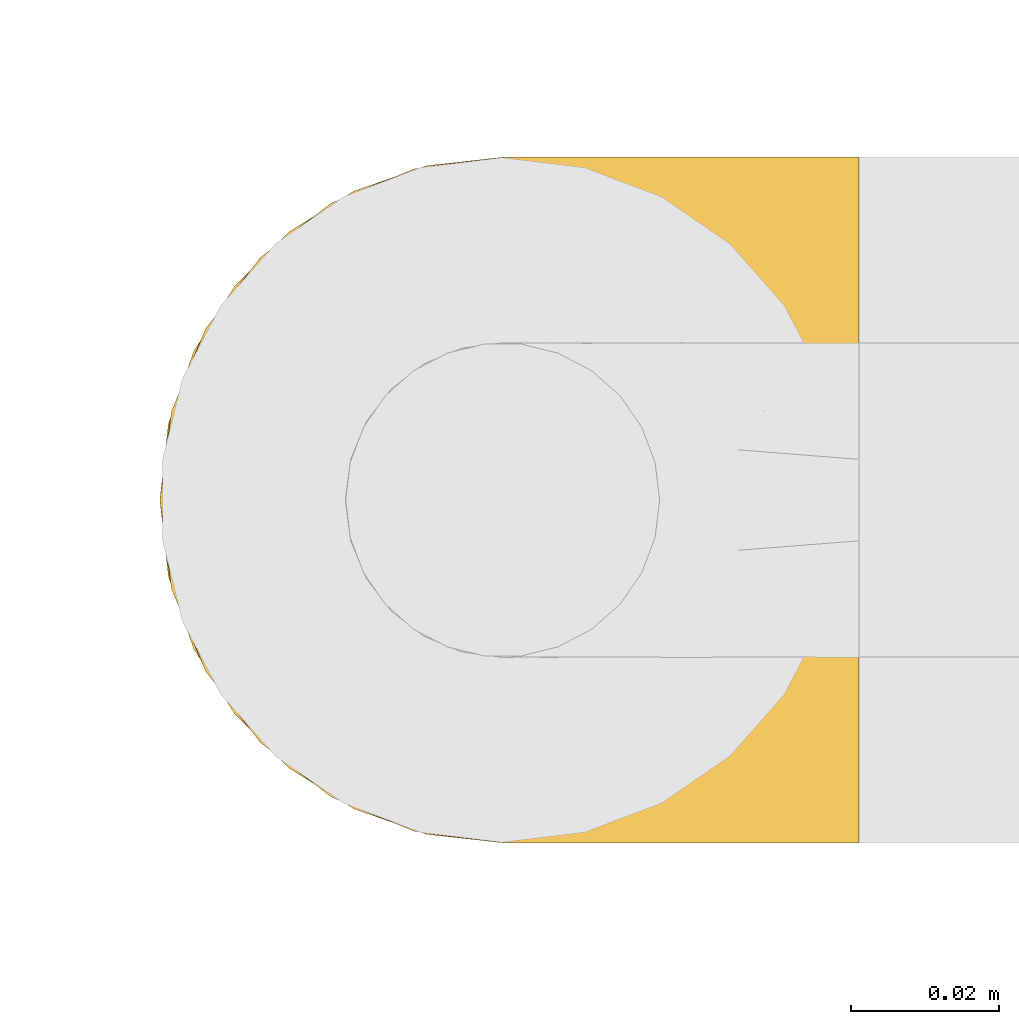
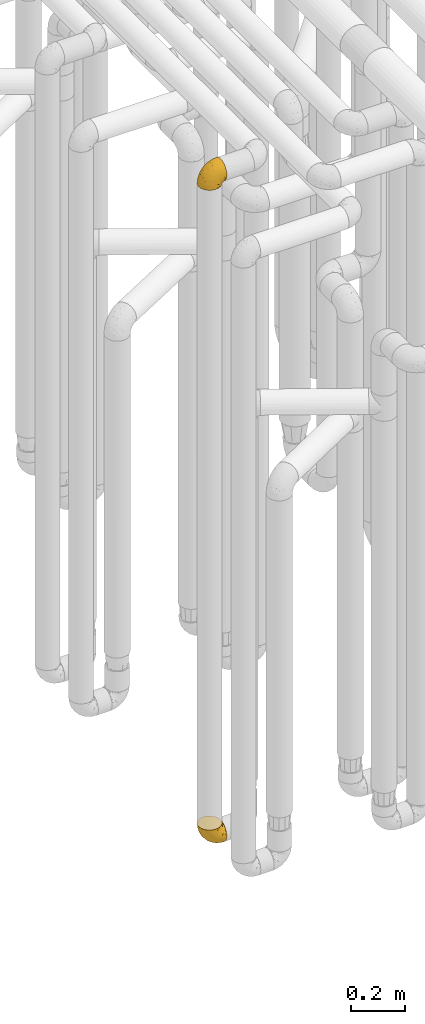
# One storey, part 153 of 827: 2 coverings.
"""IFC2X3 building model written with IfcOpenShell, lengths in millimetres."""

from ifc_helpers import new_model, entity, si_unit, converted_unit, derived_unit, direction, frame, origin, place, context, subcontext, project, spatial, faceted_brep, element, save


model = new_model("IFC2X3")

# Units and contexts
model_context = context("Model", 3, precision=0.01, world=origin(), true_north=direction((6.12303176911189e-17, 1.0)))
body_context = subcontext(model_context, "Body", "Model", "MODEL_VIEW")
ifc_project = project(units=[si_unit("LENGTHUNIT", "METRE", prefix="MILLI"), si_unit("AREAUNIT", "SQUARE_METRE"), si_unit("VOLUMEUNIT", "CUBIC_METRE"), converted_unit("PLANEANGLEUNIT", "DEGREE", entity("IfcRatioMeasure", 0.0174532925199433), si_unit("PLANEANGLEUNIT", "RADIAN"), dimensions=[0, 0, 0, 0, 0, 0, 0]), si_unit("MASSUNIT", "GRAM", prefix="KILO"), derived_unit("MASSDENSITYUNIT", [(si_unit("MASSUNIT", "GRAM", prefix="KILO"), 1), (si_unit("LENGTHUNIT", "METRE"), -3)]), derived_unit("MOMENTOFINERTIAUNIT", [(si_unit("LENGTHUNIT", "METRE"), 4)]), si_unit("TIMEUNIT", "SECOND"), si_unit("FREQUENCYUNIT", "HERTZ"), si_unit("THERMODYNAMICTEMPERATUREUNIT", "DEGREE_CELSIUS"), derived_unit("THERMALTRANSMITTANCEUNIT", [(si_unit("MASSUNIT", "GRAM", prefix="KILO"), 1), (si_unit("THERMODYNAMICTEMPERATUREUNIT", "KELVIN"), -1), (si_unit("TIMEUNIT", "SECOND"), -3)]), derived_unit("VOLUMETRICFLOWRATEUNIT", [(si_unit("LENGTHUNIT", "METRE"), 3), (si_unit("TIMEUNIT", "SECOND"), -1)]), derived_unit("MASSFLOWRATEUNIT", [(si_unit("MASSUNIT", "GRAM", prefix="KILO"), 1), (si_unit("TIMEUNIT", "SECOND"), -1)]), derived_unit("ROTATIONALFREQUENCYUNIT", [(si_unit("TIMEUNIT", "SECOND"), -1)]), si_unit("ELECTRICCURRENTUNIT", "AMPERE"), si_unit("ELECTRICVOLTAGEUNIT", "VOLT"), si_unit("POWERUNIT", "WATT"), si_unit("FORCEUNIT", "NEWTON", prefix="KILO"), si_unit("ILLUMINANCEUNIT", "LUX"), si_unit("LUMINOUSFLUXUNIT", "LUMEN"), si_unit("LUMINOUSINTENSITYUNIT", "CANDELA"), derived_unit("USERDEFINED", [(si_unit("MASSUNIT", "GRAM", prefix="KILO"), -1), (si_unit("LENGTHUNIT", "METRE"), -2), (si_unit("TIMEUNIT", "SECOND"), 3), (si_unit("LUMINOUSFLUXUNIT", "LUMEN"), 1)]), derived_unit("LINEARVELOCITYUNIT", [(si_unit("LENGTHUNIT", "METRE"), 1), (si_unit("TIMEUNIT", "SECOND"), -1)]), si_unit("PRESSUREUNIT", "PASCAL"), derived_unit("USERDEFINED", [(si_unit("LENGTHUNIT", "METRE"), -2), (si_unit("MASSUNIT", "GRAM", prefix="KILO"), 1), (si_unit("TIMEUNIT", "SECOND"), -2)]), derived_unit("LINEARFORCEUNIT", [(si_unit("MASSUNIT", "GRAM", prefix="KILO"), 1), (si_unit("LENGTHUNIT", "METRE"), 1), (si_unit("TIMEUNIT", "SECOND"), -2), (si_unit("LENGTHUNIT", "METRE"), -1)]), derived_unit("PLANARFORCEUNIT", [(si_unit("MASSUNIT", "GRAM", prefix="KILO"), 1), (si_unit("LENGTHUNIT", "METRE"), 1), (si_unit("TIMEUNIT", "SECOND"), -2), (si_unit("LENGTHUNIT", "METRE"), -2)])], contexts=[model_context])

# Site, building, storey
site_placement = place(None, origin())
site = spatial("IfcSite", under=ifc_project, at=site_placement, CompositionType="ELEMENT")
building_placement = place(site_placement, origin())
building = spatial("IfcBuilding", under=site, at=building_placement, CompositionType="ELEMENT")
storey_placement = place(building_placement, frame((0.0, 0.0, 28200.0)))
storey = spatial("IfcBuildingStorey", under=building, at=storey_placement, Name="08", CompositionType="ELEMENT", Elevation=28200.0)

# Coverings
covering_1_placement = place(storey_placement, frame((35077.24, 10561.35, 352.2)))
element("IfcCovering", 1, at=covering_1_placement, inside=storey, Name=":ADSK_", ObjectType=":ADSK_", PredefinedType="INSULATION", context=body_context, shape_type="Brep", body=[
    faceted_brep([(18.98, 83.91, 95.8), (11.67, 76.59, 95.8), (6.17, 67.83, 95.8), (2.75, 58.07, 95.8), (1.6, 47.8, 95.8), (2.75, 37.51, 95.8), (6.17, 27.74, 95.8), (11.68, 18.98, 95.8), (19.0, 11.67, 95.8), (27.76, 6.17, 95.8), (37.52, 2.75, 95.8), (47.8, 1.6, 95.8), (51.94, 2.06, 95.8), (55.01, 2.41, 95.8), (58.08, 2.75, 95.8), (62.96, 4.46, 95.8), (67.85, 6.17, 95.8), (72.23, 8.93, 95.8), (76.61, 11.68, 95.8), (80.26, 15.34, 95.8), (83.92, 19.0, 95.8), (89.42, 27.76, 95.8), (91.13, 32.64, 95.8), (92.84, 37.52, 95.8), (94.0, 47.8, 95.8), (92.84, 58.08, 95.8), (91.13, 62.96, 95.8), (89.42, 67.85, 95.8), (83.91, 76.61, 95.8), (80.25, 80.26, 95.8), (76.59, 83.92, 95.8), (72.21, 86.67, 95.8), (67.83, 89.42, 95.8), (62.95, 91.13, 95.8), (58.07, 92.84, 95.8), (55.0, 93.18, 95.8), (51.94, 93.53, 95.8), (47.8, 94.0, 95.8), (37.51, 92.84, 95.8), (27.74, 89.42, 95.8), (95.8, 47.8, 94.0), (95.8, 35.84, 92.42), (95.8, 24.7, 87.81), (95.8, 19.91, 84.13), (95.8, 15.13, 80.46), (95.8, 11.46, 75.68), (95.8, 7.78, 70.9), (95.8, 5.48, 65.32), (95.8, 3.17, 59.75), (95.8, 2.69, 56.14), (95.8, 2.42, 54.06), (95.8, 2.14, 51.97), (95.8, 1.6, 47.8), (95.8, 3.17, 35.84), (95.8, 7.78, 24.7), (95.8, 15.13, 15.13), (95.8, 24.7, 7.78), (95.8, 35.84, 3.17), (95.8, 47.8, 1.6), (95.8, 59.75, 3.17), (95.8, 70.9, 7.78), (95.8, 80.46, 15.13), (95.8, 87.81, 24.7), (95.8, 92.42, 35.84), (95.8, 94.0, 47.8), (95.8, 93.45, 51.97), (95.8, 92.9, 56.14), (95.8, 92.42, 59.75), (95.8, 90.11, 65.32), (95.8, 87.81, 70.9), (95.8, 84.13, 75.68), (95.8, 80.46, 80.46), (95.8, 75.68, 84.13), (95.8, 70.9, 87.81), (95.8, 59.75, 92.42), (60.58, 71.98, 15.84), (74.11, 63.6, 6.99), (51.59, 59.72, 14.39), (66.69, 47.8, 6.21), (76.19, 55.16, 4.26), (84.43, 47.8, 3.39), (31.2, 63.76, 31.2), (42.88, 72.22, 26.47), (79.41, 74.18, 11.44), (60.7, 92.52, 47.66), (61.85, 94.0, 61.85), (65.75, 94.0, 59.25), (69.64, 94.0, 56.65), (73.53, 94.0, 54.05), (77.43, 94.0, 51.45), (74.59, 82.14, 19.8), (54.72, 80.34, 26.22), (64.18, 87.52, 31.58), (37.94, 79.59, 38.36), (25.89, 78.25, 51.54), (34.73, 85.01, 51.6), (42.89, 90.25, 55.97), (49.83, 93.2, 62.88), (48.58, 87.23, 41.35), (22.41, 85.55, 82.24), (78.69, 93.0, 40.88), (81.64, 89.31, 29.0), (6.22, 61.31, 74.06), (12.11, 56.86, 54.53), (14.81, 68.34, 57.98), (21.61, 65.71, 43.81), (22.41, 56.99, 38.22), (30.12, 72.15, 38.33), (10.01, 70.34, 74.76), (15.36, 78.36, 76.85), (3.39, 47.8, 84.43), (19.59, 47.8, 40.43), (30.01, 47.8, 30.01), (41.19, 93.06, 78.67), (48.54, 94.0, 92.06), (49.28, 94.0, 88.32), (49.82, 94.0, 85.6), (50.37, 94.0, 82.88), (50.91, 94.0, 80.15), (51.45, 94.0, 77.43), (31.61, 89.88, 76.36), (80.15, 94.0, 50.91), (82.88, 94.0, 50.37), (85.6, 94.0, 49.82), (88.32, 94.0, 49.28), (90.19, 94.0, 48.91), (92.06, 94.0, 48.54), (6.21, 47.8, 66.69), (54.05, 94.0, 73.53), (56.65, 94.0, 69.64), (59.25, 94.0, 65.75), (24.66, 83.7, 66.13), (40.43, 47.8, 19.59), (35.17, 55.9, 24.64), (12.9, 47.8, 53.56), (53.56, 47.8, 12.9), (85.34, 81.75, 82.81), (78.44, 86.43, 81.22), (84.37, 79.8, 86.57), (89.05, 69.84, 92.75), (82.76, 79.5, 89.68), (86.31, 88.08, 72.26), (83.73, 91.6, 64.73), (77.31, 92.93, 62.45), (87.78, 92.43, 60.63), (87.91, 93.24, 56.91), (81.29, 93.36, 58.14), (93.97, 57.25, 93.7), (70.76, 89.41, 83.4), (63.67, 92.89, 75.54), (62.62, 92.66, 79.46), (90.64, 79.58, 82.28), (84.08, 86.51, 76.25), (76.28, 86.29, 84.69), (77.45, 83.91, 90.18), (88.72, 90.94, 65.12), (71.28, 91.94, 71.71), (68.09, 91.98, 75.21), (91.07, 82.79, 78.6), (57.47, 93.16, 87.27), (70.34, 88.76, 87.92), (91.35, 73.94, 86.94), (62.99, 91.89, 86.1), (94.52, 47.8, 94.52), (76.47, 92.22, 66.23), (69.96, 88.56, 91.08), (89.86, 87.72, 71.77), (78.94, 88.33, 76.21), (73.51, 92.18, 68.59), (89.62, 71.78, 89.94), (84.09, 9.09, 76.25), (86.3, 7.51, 72.26), (91.06, 12.8, 78.6), (88.32, 1.6, 49.28), (92.06, 1.6, 48.54), (82.88, 1.6, 50.37), (85.6, 1.6, 49.82), (93.97, 38.35, 93.7), (89.63, 23.84, 89.95), (50.37, 1.6, 82.88), (49.82, 1.6, 85.6), (48.54, 1.6, 92.06), (49.28, 1.6, 88.32), (82.77, 16.1, 89.68), (70.36, 6.84, 87.92), (77.31, 2.66, 62.45), (76.47, 3.37, 66.24), (69.64, 1.6, 56.65), (65.75, 1.6, 59.25), (87.78, 3.16, 60.63), (87.91, 2.35, 56.91), (89.06, 25.77, 92.76), (90.65, 16.02, 82.28), (85.35, 13.85, 82.81), (73.53, 1.6, 54.05), (77.43, 1.6, 51.45), (81.29, 2.23, 58.14), (77.46, 11.69, 90.18), (76.29, 9.31, 84.7), (57.47, 2.43, 87.25), (63.71, 2.71, 75.58), (68.11, 3.61, 75.2), (70.77, 6.18, 83.39), (71.31, 3.66, 71.7), (78.46, 9.17, 81.22), (69.52, 6.77, 90.73), (62.64, 2.93, 79.47), (91.35, 21.66, 86.94), (59.25, 1.6, 65.75), (84.6, 16.09, 86.75), (62.98, 3.7, 86.08), (51.45, 1.6, 77.43), (54.05, 1.6, 73.53), (56.65, 1.6, 69.64), (83.73, 3.99, 64.73), (80.15, 1.6, 50.91), (88.72, 4.65, 65.12), (61.85, 1.6, 61.85), (73.56, 3.43, 68.62), (78.96, 7.27, 76.22), (91.36, 9.46, 74.03), (50.91, 1.6, 80.15), (62.87, 2.4, 49.81), (76.19, 40.43, 4.26), (73.57, 13.57, 19.95), (56.07, 11.3, 30.61), (49.77, 18.65, 25.71), (44.73, 27.26, 22.43), (60.58, 23.61, 15.85), (47.64, 3.07, 60.69), (78.32, 2.69, 40.49), (51.59, 35.87, 14.39), (74.11, 31.99, 6.99), (76.04, 6.71, 29.56), (79.41, 21.41, 11.45), (14.82, 27.24, 57.98), (6.22, 34.26, 74.06), (12.12, 38.73, 54.52), (23.51, 26.97, 43.47), (31.2, 31.83, 31.2), (34.96, 23.4, 33.27), (33.86, 6.91, 64.26), (38.94, 3.4, 74.29), (30.23, 5.84, 80.41), (35.17, 39.69, 24.64), (15.85, 17.6, 73.62), (22.59, 10.38, 78.98), (21.56, 20.6, 53.69), (55.94, 5.36, 42.86), (20.67, 35.73, 41.67), (9.19, 24.84, 79.66), (25.79, 13.87, 58.41), (41.16, 9.06, 47.11), (37.95, 15.99, 38.37)], [[[0, 1, 2, 3, 4, 5, 6, 7, 8, 9, 10, 11, 12, 13, 14, 15, 16, 17, 18, 19, 20, 21, 22, 23, 24, 25, 26, 27, 28, 29, 30, 31, 32, 33, 34, 35, 36, 37, 38, 39]], [[40, 41, 42, 43, 44, 45, 46, 47, 48, 49, 50, 51, 52, 53, 54, 55, 56, 57, 58, 59, 60, 61, 62, 63, 64, 65, 66, 67, 68, 69, 70, 71, 72, 73, 74]], [[75, 76, 77]], [[78, 79, 80]], [[77, 81, 82]], [[76, 75, 83]], [[84, 85, 86, 87, 88, 89]], [[90, 91, 92]], [[76, 60, 59]], [[93, 94, 95]], [[90, 62, 61]], [[83, 61, 60]], [[96, 97, 84]], [[98, 93, 95]], [[0, 39, 99]], [[100, 84, 89]], [[62, 101, 63]], [[2, 102, 3]], [[92, 84, 100]], [[103, 102, 104]], [[103, 105, 106]], [[93, 107, 94]], [[1, 108, 2]], [[92, 101, 90]], [[108, 1, 109]], [[102, 110, 3]], [[93, 82, 107]], [[102, 108, 104]], [[111, 106, 112]], [[109, 0, 99]], [[113, 37, 114, 115, 116, 117, 118, 119]], [[120, 38, 113]], [[100, 89, 121, 122, 123, 124, 125, 126, 64]], [[127, 102, 103]], [[97, 119, 128, 129, 130, 85]], [[99, 120, 131]], [[132, 133, 77]], [[59, 80, 79]], [[1, 0, 109]], [[98, 84, 92]], [[94, 109, 131]], [[120, 39, 38]], [[93, 91, 82]], [[104, 94, 105]], [[97, 113, 119]], [[95, 120, 96]], [[83, 90, 61]], [[91, 93, 98]], [[64, 63, 100]], [[100, 63, 101]], [[77, 76, 79]], [[133, 106, 81]], [[84, 97, 85]], [[113, 96, 120]], [[113, 97, 96]], [[37, 113, 38]], [[110, 102, 127]], [[110, 4, 3]], [[103, 111, 134, 127]], [[90, 75, 91]], [[82, 81, 107]], [[91, 75, 82]], [[77, 82, 75]], [[76, 83, 60]], [[90, 83, 75]], [[105, 107, 81]], [[94, 131, 95]], [[105, 94, 107]], [[109, 94, 104]], [[120, 95, 131]], [[98, 95, 96]], [[84, 98, 96]], [[98, 92, 91]], [[106, 105, 81]], [[103, 104, 105]], [[112, 106, 133]], [[103, 106, 111]], [[112, 133, 132]], [[81, 77, 133]], [[77, 78, 135, 132]], [[120, 99, 39]], [[109, 99, 131]], [[59, 58, 80]], [[59, 79, 76]], [[90, 101, 62]], [[100, 101, 92]], [[2, 108, 102]], [[109, 104, 108]], [[78, 77, 79]], [[136, 137, 138]], [[27, 139, 140]], [[141, 142, 143]], [[144, 145, 121]], [[146, 89, 88]], [[147, 139, 25]], [[148, 149, 150]], [[136, 151, 152]], [[147, 40, 74]], [[24, 147, 25]], [[140, 153, 154]], [[33, 116, 34]], [[73, 72, 151]], [[114, 37, 36, 35, 34, 116, 115]], [[146, 155, 144]], [[156, 85, 130]], [[157, 149, 148]], [[151, 158, 152]], [[117, 33, 159]], [[29, 154, 160]], [[161, 74, 73]], [[162, 128, 119]], [[66, 65, 64, 126, 125, 124, 123, 122, 67]], [[163, 147, 24]], [[27, 140, 28]], [[149, 129, 150]], [[139, 27, 26, 25]], [[68, 144, 69]], [[129, 128, 150]], [[164, 87, 86]], [[130, 129, 149]], [[122, 145, 67]], [[154, 153, 148]], [[162, 119, 159]], [[165, 30, 160]], [[150, 160, 148]], [[128, 162, 150]], [[30, 165, 31]], [[145, 144, 68]], [[89, 146, 144]], [[87, 164, 143]], [[166, 155, 142]], [[88, 87, 143]], [[162, 160, 150]], [[160, 30, 29]], [[154, 29, 28]], [[140, 154, 28]], [[160, 154, 148]], [[140, 137, 153]], [[157, 148, 153]], [[156, 130, 157]], [[153, 137, 157]], [[157, 137, 156]], [[167, 137, 136]], [[168, 85, 156]], [[152, 168, 167]], [[167, 168, 156]], [[164, 152, 141]], [[71, 158, 72]], [[152, 167, 136]], [[88, 142, 146]], [[144, 155, 69]], [[146, 142, 155]], [[70, 166, 71]], [[142, 141, 166]], [[70, 69, 155]], [[141, 158, 71]], [[161, 73, 151]], [[138, 137, 140]], [[161, 136, 169]], [[136, 161, 151]], [[74, 161, 169]], [[152, 158, 141]], [[151, 72, 158]], [[168, 152, 164]], [[137, 167, 156]], [[164, 86, 168]], [[85, 168, 86]], [[116, 33, 117]], [[130, 149, 157]], [[67, 145, 68]], [[121, 89, 144]], [[145, 122, 121]], [[40, 147, 163]], [[169, 147, 74]], [[159, 33, 32]], [[162, 159, 32]], [[159, 119, 118, 117]], [[139, 147, 169]], [[139, 169, 138]], [[162, 32, 31]], [[141, 143, 164]], [[88, 143, 142]], [[71, 166, 141]], [[155, 166, 70]], [[139, 138, 140]], [[169, 136, 138]], [[160, 162, 165]], [[162, 31, 165]], [[170, 171, 172]], [[173, 174, 52, 51, 50, 49, 48, 175, 176]], [[177, 178, 41]], [[179, 15, 180]], [[12, 11, 181, 182, 180, 14, 13]], [[183, 21, 20]], [[19, 18, 184]], [[185, 186, 187]], [[186, 188, 187]], [[43, 172, 44]], [[189, 190, 47]], [[23, 22, 21, 191]], [[170, 192, 193]], [[40, 163, 177]], [[194, 195, 196]], [[24, 23, 177]], [[197, 198, 183]], [[199, 15, 179]], [[47, 46, 189]], [[200, 201, 202]], [[201, 203, 204]], [[205, 206, 184]], [[207, 41, 178]], [[16, 15, 199]], [[14, 180, 15]], [[202, 201, 198]], [[208, 201, 200]], [[163, 24, 177]], [[48, 47, 190]], [[196, 195, 189]], [[197, 184, 202]], [[204, 193, 209]], [[210, 211, 212]], [[206, 212, 213]], [[205, 17, 210]], [[184, 206, 202]], [[210, 212, 206]], [[185, 194, 214]], [[189, 215, 190]], [[216, 45, 214]], [[186, 171, 170]], [[189, 216, 196]], [[197, 20, 19]], [[194, 185, 187]], [[197, 183, 20]], [[184, 197, 19]], [[197, 202, 198]], [[206, 200, 202]], [[204, 183, 198]], [[201, 208, 203]], [[203, 208, 217]], [[204, 198, 201]], [[217, 188, 218]], [[193, 219, 170]], [[171, 186, 185]], [[170, 218, 186]], [[170, 219, 218]], [[42, 207, 192]], [[171, 220, 172]], [[216, 189, 46]], [[214, 194, 196]], [[44, 220, 45]], [[214, 196, 216]], [[216, 46, 45]], [[214, 45, 220]], [[192, 43, 42]], [[204, 203, 219]], [[207, 193, 192]], [[209, 193, 178]], [[41, 207, 42]], [[193, 207, 178]], [[43, 192, 172]], [[170, 172, 192]], [[204, 219, 193]], [[219, 203, 218]], [[217, 218, 203]], [[188, 186, 218]], [[206, 213, 200]], [[208, 200, 213]], [[199, 210, 16]], [[215, 189, 195]], [[215, 175, 190]], [[175, 48, 190]], [[199, 179, 221, 211]], [[210, 199, 211]], [[23, 191, 177]], [[40, 177, 41]], [[178, 177, 191]], [[21, 183, 191]], [[209, 191, 183]], [[205, 18, 17]], [[17, 16, 210]], [[171, 185, 214]], [[172, 220, 44]], [[214, 220, 171]], [[191, 209, 178]], [[204, 209, 183]], [[206, 205, 210]], [[18, 205, 184]], [[222, 195, 194, 187, 188, 217]], [[57, 223, 80]], [[224, 225, 226]], [[226, 227, 228]], [[229, 217, 208, 213, 212, 211]], [[230, 52, 174, 173, 176, 175, 215, 195]], [[231, 232, 228]], [[231, 78, 223]], [[223, 57, 232]], [[224, 233, 225]], [[233, 54, 53]], [[234, 232, 56]], [[56, 55, 234]], [[234, 224, 228]], [[235, 236, 237]], [[224, 55, 54]], [[238, 239, 240]], [[52, 230, 53]], [[241, 242, 243]], [[227, 244, 231]], [[11, 10, 242]], [[236, 6, 5]], [[7, 245, 8]], [[8, 246, 9]], [[238, 247, 235]], [[222, 229, 248]], [[242, 211, 221, 179, 180, 182, 181, 11]], [[233, 53, 230]], [[111, 112, 249]], [[250, 6, 236]], [[246, 251, 241]], [[6, 250, 7]], [[127, 236, 110]], [[248, 229, 252]], [[246, 8, 245]], [[235, 245, 250]], [[236, 5, 110]], [[235, 249, 238]], [[237, 236, 127]], [[243, 9, 246]], [[252, 229, 241]], [[56, 232, 57]], [[222, 230, 195]], [[225, 248, 252]], [[248, 233, 230]], [[54, 233, 224]], [[231, 228, 227]], [[244, 132, 231]], [[248, 225, 233]], [[226, 225, 253]], [[235, 250, 236]], [[245, 7, 250]], [[251, 246, 245]], [[243, 246, 241]], [[247, 245, 235]], [[252, 251, 253]], [[229, 222, 217]], [[230, 222, 248]], [[5, 4, 110]], [[237, 127, 134, 111]], [[238, 249, 239]], [[224, 234, 55]], [[232, 234, 228]], [[242, 241, 229]], [[10, 9, 243]], [[211, 242, 229]], [[10, 243, 242]], [[80, 223, 78]], [[80, 58, 57]], [[231, 223, 232]], [[227, 240, 239]], [[224, 226, 228]], [[240, 226, 253]], [[227, 239, 244]], [[226, 240, 227]], [[251, 247, 253]], [[240, 253, 247]], [[249, 235, 237]], [[237, 111, 249]], [[112, 132, 244]], [[112, 244, 249]], [[78, 231, 132, 135]], [[249, 244, 239]], [[247, 238, 240]], [[245, 247, 251]], [[251, 252, 241]], [[225, 252, 253]]]),
])
covering_2_placement = place(storey_placement, frame((35077.24, 10561.35, 3350.4)))
element("IfcCovering", 2, at=covering_2_placement, inside=storey, Name=":ADSK_", ObjectType=":ADSK_", PredefinedType="INSULATION", context=body_context, shape_type="Brep", body=[
    faceted_brep([(95.8, 83.91, 78.41), (95.8, 76.59, 85.72), (95.8, 67.83, 91.22), (95.8, 58.07, 94.64), (95.8, 47.8, 95.8), (95.8, 37.51, 94.64), (95.8, 27.74, 91.22), (95.8, 18.98, 85.71), (95.8, 11.67, 78.39), (95.8, 6.17, 69.63), (95.8, 2.75, 59.87), (95.8, 1.6, 49.6), (95.8, 2.06, 45.45), (95.8, 2.41, 42.38), (95.8, 2.75, 39.31), (95.8, 4.46, 34.43), (95.8, 6.17, 29.54), (95.8, 8.93, 25.16), (95.8, 11.68, 20.78), (95.8, 15.34, 17.13), (95.8, 19.0, 13.47), (95.8, 27.76, 7.97), (95.8, 32.64, 6.26), (95.8, 37.52, 4.55), (95.8, 47.8, 3.4), (95.8, 58.08, 4.55), (95.8, 62.96, 6.26), (95.8, 67.85, 7.97), (95.8, 76.61, 13.48), (95.8, 80.26, 17.14), (95.8, 83.92, 20.8), (95.8, 86.67, 25.18), (95.8, 89.42, 29.56), (95.8, 91.13, 34.44), (95.8, 92.84, 39.32), (95.8, 93.18, 42.39), (95.8, 93.53, 45.45), (95.8, 94.0, 49.6), (95.8, 92.84, 59.88), (95.8, 89.42, 69.65), (94.0, 47.8, 1.6), (92.42, 35.84, 1.6), (87.81, 24.7, 1.6), (84.13, 19.91, 1.6), (80.46, 15.13, 1.6), (75.68, 11.46, 1.6), (70.9, 7.78, 1.6), (65.32, 5.48, 1.6), (59.75, 3.17, 1.6), (56.14, 2.69, 1.6), (54.06, 2.42, 1.6), (51.97, 2.14, 1.6), (47.8, 1.6, 1.6), (35.84, 3.17, 1.6), (24.7, 7.78, 1.6), (15.13, 15.13, 1.6), (7.78, 24.7, 1.6), (3.17, 35.84, 1.6), (1.6, 47.8, 1.6), (3.17, 59.75, 1.6), (7.78, 70.9, 1.6), (15.13, 80.46, 1.6), (24.7, 87.81, 1.6), (35.84, 92.42, 1.6), (47.8, 94.0, 1.6), (51.97, 93.45, 1.6), (56.14, 92.9, 1.6), (59.75, 92.42, 1.6), (65.32, 90.11, 1.6), (70.9, 87.81, 1.6), (75.68, 84.13, 1.6), (80.46, 80.46, 1.6), (84.13, 75.68, 1.6), (87.81, 70.9, 1.6), (92.42, 59.75, 1.6), (15.84, 71.98, 36.81), (6.99, 63.6, 23.28), (14.39, 59.72, 45.8), (6.21, 47.8, 30.7), (4.26, 55.16, 21.2), (3.39, 47.8, 12.96), (31.2, 63.76, 66.19), (26.47, 72.22, 54.51), (11.44, 74.18, 17.98), (47.66, 92.52, 36.69), (61.85, 94.0, 35.54), (59.25, 94.0, 31.64), (56.65, 94.0, 27.75), (54.05, 94.0, 23.86), (51.45, 94.0, 19.96), (19.8, 82.14, 22.8), (26.22, 80.34, 42.67), (31.58, 87.52, 33.21), (38.36, 79.59, 59.45), (51.54, 78.25, 71.5), (51.6, 85.01, 62.66), (55.97, 90.25, 54.5), (62.88, 93.2, 47.57), (41.35, 87.23, 48.81), (82.24, 85.55, 74.98), (40.88, 93.0, 18.7), (29.0, 89.31, 15.75), (74.06, 61.31, 91.17), (54.53, 56.86, 85.28), (57.98, 68.34, 82.58), (43.81, 65.71, 75.78), (38.22, 56.99, 74.98), (38.33, 72.15, 67.27), (74.76, 70.34, 87.38), (76.85, 78.36, 82.04), (84.43, 47.8, 94.0), (40.43, 47.8, 77.8), (30.01, 47.8, 67.38), (78.67, 93.06, 56.2), (92.06, 94.0, 48.85), (88.32, 94.0, 48.11), (85.6, 94.0, 47.57), (82.88, 94.0, 47.03), (80.15, 94.0, 46.48), (77.43, 94.0, 45.94), (76.36, 89.88, 65.78), (50.91, 94.0, 17.24), (50.37, 94.0, 14.51), (49.82, 94.0, 11.79), (49.28, 94.0, 9.07), (48.91, 94.0, 7.2), (48.54, 94.0, 5.33), (66.69, 47.8, 91.18), (73.53, 94.0, 43.34), (69.64, 94.0, 40.74), (65.75, 94.0, 38.14), (66.13, 83.7, 72.73), (19.59, 47.8, 56.96), (24.64, 55.9, 62.23), (53.56, 47.8, 84.49), (12.9, 47.8, 43.83), (82.81, 81.75, 12.05), (81.22, 86.43, 18.95), (86.57, 79.8, 13.02), (92.75, 69.84, 8.34), (89.68, 79.5, 14.63), (72.26, 88.08, 11.09), (64.73, 91.6, 13.66), (62.45, 92.93, 20.08), (60.63, 92.43, 9.61), (56.91, 93.24, 9.48), (58.14, 93.36, 16.1), (93.7, 57.25, 3.42), (83.4, 89.41, 26.63), (75.54, 92.89, 33.72), (79.46, 92.66, 34.77), (82.28, 79.58, 6.75), (76.25, 86.51, 13.31), (90.18, 83.91, 19.94), (84.69, 86.29, 21.11), (86.94, 73.94, 6.04), (65.12, 90.94, 8.67), (71.71, 91.94, 26.11), (75.21, 91.98, 29.3), (78.6, 82.79, 6.32), (87.27, 93.16, 39.92), (87.92, 88.76, 27.05), (86.1, 91.89, 34.4), (94.52, 47.8, 2.87), (66.23, 92.22, 20.92), (91.08, 88.56, 27.43), (71.77, 87.72, 7.54), (76.21, 88.33, 18.45), (68.59, 92.18, 23.88), (89.94, 71.78, 7.77), (76.22, 7.27, 18.43), (81.22, 9.17, 18.93), (71.7, 3.66, 26.08), (49.28, 1.6, 9.07), (48.54, 1.6, 5.33), (50.37, 1.6, 14.51), (49.82, 1.6, 11.79), (93.7, 38.35, 3.42), (89.95, 23.84, 7.76), (82.88, 1.6, 47.03), (85.6, 1.6, 47.57), (92.06, 1.6, 48.85), (88.32, 1.6, 48.11), (89.68, 16.1, 14.62), (87.92, 6.84, 27.03), (62.45, 2.66, 20.08), (66.24, 3.37, 20.92), (56.65, 1.6, 27.75), (59.25, 1.6, 31.64), (78.6, 12.8, 6.33), (60.63, 3.16, 9.61), (56.91, 2.35, 9.48), (92.76, 25.77, 8.33), (76.25, 9.09, 13.3), (82.28, 16.02, 6.74), (82.81, 13.85, 12.04), (54.05, 1.6, 23.86), (51.45, 1.6, 19.96), (58.14, 2.23, 16.1), (90.18, 11.69, 19.93), (84.7, 9.31, 21.1), (87.25, 2.43, 39.92), (75.58, 2.71, 33.68), (75.2, 3.61, 29.28), (83.39, 6.18, 26.62), (90.73, 6.77, 27.87), (79.47, 2.93, 34.75), (86.94, 21.66, 6.04), (65.75, 1.6, 38.14), (86.75, 16.09, 12.79), (86.08, 3.7, 34.41), (77.43, 1.6, 45.94), (73.53, 1.6, 43.34), (69.64, 1.6, 40.74), (64.73, 3.99, 13.66), (50.91, 1.6, 17.24), (65.12, 4.65, 8.67), (72.26, 7.51, 11.09), (61.85, 1.6, 35.54), (68.62, 3.43, 23.83), (74.03, 9.46, 6.03), (80.15, 1.6, 46.48), (49.81, 2.4, 34.52), (4.26, 40.43, 21.2), (19.95, 13.57, 23.82), (30.61, 11.3, 41.32), (25.71, 18.65, 47.62), (22.43, 27.26, 52.66), (15.85, 23.61, 36.81), (60.69, 3.07, 49.75), (40.49, 2.69, 19.07), (14.39, 35.87, 45.8), (6.99, 31.99, 23.28), (29.56, 6.71, 21.35), (11.45, 21.41, 17.98), (57.98, 27.24, 82.57), (74.06, 34.26, 91.17), (54.52, 38.73, 85.27), (43.47, 26.97, 73.89), (31.2, 31.83, 66.19), (33.27, 23.4, 62.43), (64.26, 6.91, 63.53), (74.29, 3.4, 58.45), (80.41, 5.84, 67.16), (41.67, 35.73, 76.72), (24.64, 39.69, 62.22), (73.62, 17.6, 81.54), (78.98, 10.38, 74.8), (53.69, 20.6, 75.83), (42.86, 5.36, 41.45), (79.66, 24.84, 88.2), (58.41, 13.87, 71.6), (47.11, 9.06, 56.23), (38.37, 15.99, 59.44)], [[[0, 1, 2, 3, 4, 5, 6, 7, 8, 9, 10, 11, 12, 13, 14, 15, 16, 17, 18, 19, 20, 21, 22, 23, 24, 25, 26, 27, 28, 29, 30, 31, 32, 33, 34, 35, 36, 37, 38, 39]], [[40, 41, 42, 43, 44, 45, 46, 47, 48, 49, 50, 51, 52, 53, 54, 55, 56, 57, 58, 59, 60, 61, 62, 63, 64, 65, 66, 67, 68, 69, 70, 71, 72, 73, 74]], [[75, 76, 77]], [[78, 79, 80]], [[77, 81, 82]], [[76, 75, 83]], [[84, 85, 86, 87, 88, 89]], [[90, 91, 92]], [[76, 60, 59]], [[93, 94, 95]], [[90, 62, 61]], [[83, 61, 60]], [[96, 97, 84]], [[98, 93, 95]], [[0, 39, 99]], [[100, 84, 89]], [[62, 101, 63]], [[2, 102, 3]], [[92, 84, 100]], [[103, 102, 104]], [[103, 105, 106]], [[93, 107, 94]], [[1, 108, 2]], [[92, 101, 90]], [[108, 1, 109]], [[102, 110, 3]], [[93, 82, 107]], [[102, 108, 104]], [[111, 106, 112]], [[109, 0, 99]], [[113, 37, 114, 115, 116, 117, 118, 119]], [[120, 38, 113]], [[100, 89, 121, 122, 123, 124, 125, 126, 64]], [[127, 102, 103]], [[97, 119, 128, 129, 130, 85]], [[99, 120, 131]], [[132, 133, 77]], [[59, 80, 79]], [[1, 0, 109]], [[98, 84, 92]], [[94, 109, 131]], [[120, 39, 38]], [[93, 91, 82]], [[104, 94, 105]], [[97, 113, 119]], [[95, 120, 96]], [[83, 90, 61]], [[91, 93, 98]], [[64, 63, 100]], [[100, 63, 101]], [[77, 76, 79]], [[133, 106, 81]], [[84, 97, 85]], [[113, 96, 120]], [[113, 97, 96]], [[37, 113, 38]], [[110, 102, 127]], [[110, 4, 3]], [[103, 111, 134, 127]], [[90, 75, 91]], [[82, 81, 107]], [[91, 75, 82]], [[77, 82, 75]], [[76, 83, 60]], [[90, 83, 75]], [[105, 107, 81]], [[94, 131, 95]], [[105, 94, 107]], [[109, 94, 104]], [[120, 95, 131]], [[98, 95, 96]], [[84, 98, 96]], [[98, 92, 91]], [[106, 105, 81]], [[103, 104, 105]], [[112, 106, 133]], [[103, 106, 111]], [[112, 133, 132]], [[81, 77, 133]], [[77, 78, 135, 132]], [[120, 99, 39]], [[109, 99, 131]], [[59, 58, 80]], [[59, 79, 76]], [[90, 101, 62]], [[100, 101, 92]], [[2, 108, 102]], [[109, 104, 108]], [[78, 77, 79]], [[136, 137, 138]], [[27, 139, 140]], [[141, 142, 143]], [[144, 145, 121]], [[146, 89, 88]], [[147, 139, 25]], [[148, 149, 150]], [[136, 151, 152]], [[147, 40, 74]], [[24, 147, 25]], [[153, 140, 154]], [[33, 116, 34]], [[73, 151, 155]], [[114, 37, 36, 35, 34, 116, 115]], [[146, 156, 144]], [[157, 85, 130]], [[158, 149, 148]], [[151, 159, 152]], [[117, 33, 160]], [[29, 153, 161]], [[155, 74, 73]], [[162, 128, 119]], [[66, 65, 64, 126, 125, 124, 123, 122, 67]], [[163, 147, 24]], [[27, 140, 28]], [[149, 129, 150]], [[139, 27, 26, 25]], [[68, 144, 69]], [[129, 128, 150]], [[164, 87, 86]], [[130, 129, 149]], [[122, 145, 67]], [[153, 154, 148]], [[162, 119, 160]], [[165, 30, 161]], [[150, 161, 148]], [[128, 162, 150]], [[30, 165, 31]], [[145, 144, 68]], [[89, 146, 144]], [[87, 164, 143]], [[166, 156, 142]], [[88, 87, 143]], [[162, 161, 150]], [[161, 30, 29]], [[161, 153, 148]], [[28, 140, 153]], [[29, 28, 153]], [[140, 137, 154]], [[158, 148, 154]], [[157, 130, 158]], [[154, 137, 158]], [[158, 137, 157]], [[167, 137, 136]], [[168, 85, 157]], [[152, 168, 167]], [[167, 168, 157]], [[164, 152, 141]], [[151, 73, 72]], [[159, 72, 71]], [[88, 142, 146]], [[144, 156, 69]], [[146, 142, 156]], [[70, 166, 71]], [[142, 141, 166]], [[70, 69, 156]], [[141, 159, 71]], [[167, 136, 152]], [[138, 137, 140]], [[155, 136, 169]], [[136, 155, 151]], [[74, 155, 169]], [[152, 159, 141]], [[151, 72, 159]], [[168, 152, 164]], [[137, 167, 157]], [[164, 86, 168]], [[85, 168, 86]], [[116, 33, 117]], [[130, 149, 158]], [[67, 145, 68]], [[121, 89, 144]], [[145, 122, 121]], [[40, 147, 163]], [[169, 147, 74]], [[160, 33, 32]], [[162, 160, 32]], [[160, 119, 118, 117]], [[139, 147, 169]], [[139, 169, 138]], [[162, 32, 31]], [[141, 143, 164]], [[88, 143, 142]], [[71, 166, 141]], [[156, 166, 70]], [[139, 138, 140]], [[169, 136, 138]], [[161, 162, 165]], [[162, 31, 165]], [[170, 171, 172]], [[173, 174, 52, 51, 50, 49, 48, 175, 176]], [[177, 178, 41]], [[179, 15, 180]], [[12, 11, 181, 182, 180, 14, 13]], [[183, 21, 20]], [[19, 18, 184]], [[185, 186, 187]], [[186, 188, 187]], [[43, 189, 44]], [[190, 191, 47]], [[23, 22, 21, 192]], [[193, 194, 195]], [[40, 163, 177]], [[196, 197, 198]], [[24, 23, 177]], [[199, 200, 183]], [[201, 15, 179]], [[178, 177, 192]], [[47, 46, 190]], [[202, 203, 204]], [[203, 172, 171]], [[205, 206, 184]], [[207, 41, 178]], [[16, 15, 201]], [[14, 180, 15]], [[204, 203, 200]], [[208, 203, 202]], [[163, 24, 177]], [[48, 47, 191]], [[198, 197, 190]], [[199, 184, 204]], [[171, 195, 209]], [[210, 211, 212]], [[206, 212, 213]], [[205, 17, 210]], [[184, 206, 204]], [[210, 212, 206]], [[185, 196, 214]], [[190, 215, 191]], [[216, 45, 214]], [[186, 217, 193]], [[190, 216, 198]], [[199, 20, 19]], [[196, 185, 187]], [[199, 183, 20]], [[184, 199, 19]], [[199, 204, 200]], [[206, 202, 204]], [[171, 183, 200]], [[203, 208, 172]], [[172, 208, 218]], [[171, 200, 203]], [[218, 188, 219]], [[195, 170, 193]], [[217, 186, 185]], [[193, 219, 186]], [[193, 170, 219]], [[207, 194, 42]], [[217, 220, 189]], [[216, 190, 46]], [[214, 196, 198]], [[44, 220, 45]], [[214, 198, 216]], [[216, 46, 45]], [[214, 45, 220]], [[42, 194, 43]], [[189, 193, 217]], [[207, 195, 194]], [[209, 195, 178]], [[41, 207, 42]], [[195, 207, 178]], [[43, 194, 189]], [[193, 189, 194]], [[171, 170, 195]], [[170, 172, 219]], [[218, 219, 172]], [[188, 186, 219]], [[206, 213, 202]], [[208, 202, 213]], [[201, 210, 16]], [[215, 190, 197]], [[215, 175, 191]], [[175, 48, 191]], [[201, 179, 221, 211]], [[210, 201, 211]], [[23, 192, 177]], [[40, 177, 41]], [[192, 183, 209]], [[21, 183, 192]], [[205, 18, 17]], [[17, 16, 210]], [[217, 185, 214]], [[189, 220, 44]], [[214, 220, 217]], [[192, 209, 178]], [[171, 209, 183]], [[206, 205, 210]], [[18, 205, 184]], [[222, 197, 196, 187, 188, 218]], [[57, 223, 80]], [[224, 225, 226]], [[226, 227, 228]], [[229, 218, 208, 213, 212, 211]], [[230, 52, 174, 173, 176, 175, 215, 197]], [[231, 232, 228]], [[231, 78, 223]], [[223, 57, 232]], [[224, 233, 225]], [[233, 54, 53]], [[234, 232, 56]], [[56, 55, 234]], [[234, 224, 228]], [[235, 236, 237]], [[224, 55, 54]], [[238, 239, 240]], [[52, 230, 53]], [[241, 242, 243]], [[239, 244, 245]], [[11, 10, 242]], [[236, 6, 5]], [[7, 246, 8]], [[8, 247, 9]], [[238, 248, 235]], [[222, 229, 249]], [[242, 211, 221, 179, 180, 182, 181, 11]], [[233, 53, 230]], [[111, 112, 244]], [[250, 6, 236]], [[247, 251, 241]], [[6, 250, 7]], [[127, 236, 110]], [[249, 229, 252]], [[247, 8, 246]], [[235, 246, 250]], [[236, 5, 110]], [[235, 244, 238]], [[237, 236, 127]], [[243, 9, 247]], [[252, 229, 241]], [[56, 232, 57]], [[222, 230, 197]], [[225, 249, 252]], [[249, 233, 230]], [[54, 233, 224]], [[231, 228, 227]], [[245, 132, 231]], [[249, 225, 233]], [[226, 225, 253]], [[235, 250, 236]], [[246, 7, 250]], [[251, 247, 246]], [[243, 247, 241]], [[248, 246, 235]], [[252, 251, 253]], [[229, 222, 218]], [[230, 222, 249]], [[5, 4, 110]], [[237, 127, 134, 111]], [[238, 244, 239]], [[224, 234, 55]], [[232, 234, 228]], [[242, 241, 229]], [[10, 9, 243]], [[211, 242, 229]], [[10, 243, 242]], [[80, 223, 78]], [[80, 58, 57]], [[231, 223, 232]], [[227, 240, 239]], [[224, 226, 228]], [[240, 226, 253]], [[227, 239, 245]], [[226, 240, 227]], [[251, 248, 253]], [[240, 253, 248]], [[244, 235, 237]], [[237, 111, 244]], [[132, 245, 112]], [[112, 245, 244]], [[135, 78, 231, 132]], [[227, 245, 231]], [[248, 238, 240]], [[246, 248, 251]], [[251, 252, 241]], [[225, 252, 253]]]),
])

save(model, "model.ifc")
